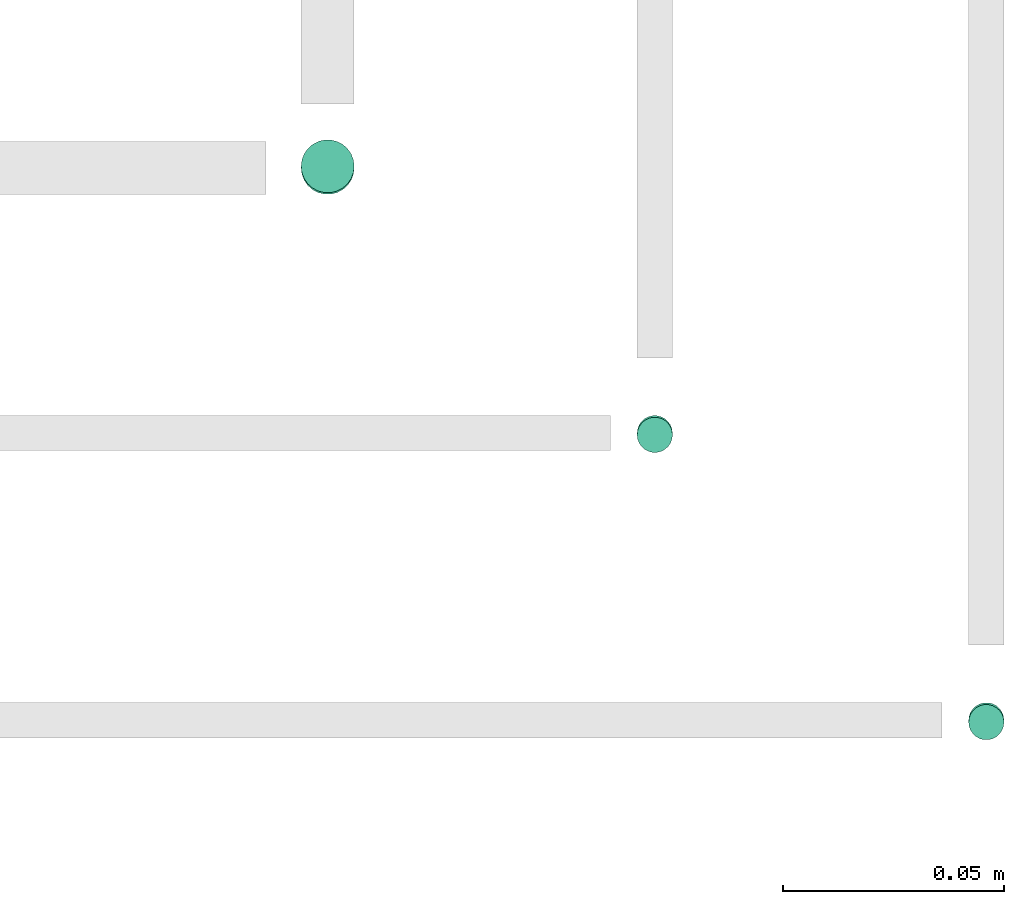
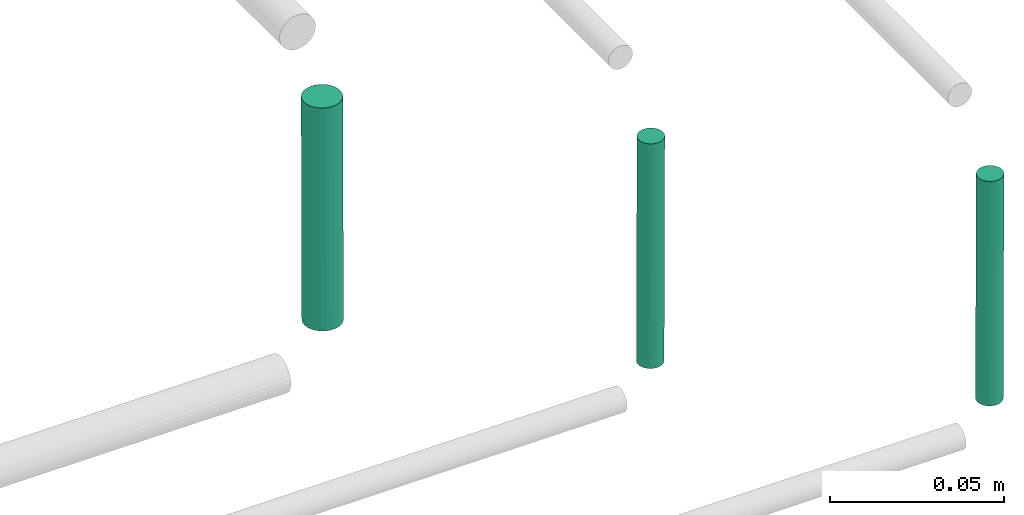
# One storey, part 290 of 331: 3 flow segments.
"""IFC2X3 building model written with IfcOpenShell, lengths in millimetres."""

from ifc_helpers import new_model, entity, si_unit, converted_unit, derived_unit, direction, frame, frame_2d, origin, origin_2d_with_axis, place, context, subcontext, project, spatial, circle, extrude, type_object, element, save


model = new_model("IFC2X3")

# Units and contexts
model_context = context("Model", 3, precision=0.01, world=origin(), true_north=direction((6.12303176911189e-17, 1.0)))
body_context = subcontext(model_context, "Body", "Model", "MODEL_VIEW")
ifc_project = project(units=[si_unit("LENGTHUNIT", "METRE", prefix="MILLI"), si_unit("AREAUNIT", "SQUARE_METRE"), si_unit("VOLUMEUNIT", "CUBIC_METRE"), converted_unit("PLANEANGLEUNIT", "DEGREE", entity("IfcRatioMeasure", 0.0174532925199433), si_unit("PLANEANGLEUNIT", "RADIAN"), dimensions=[0, 0, 0, 0, 0, 0, 0]), si_unit("MASSUNIT", "GRAM", prefix="KILO"), derived_unit("MASSDENSITYUNIT", [(si_unit("MASSUNIT", "GRAM", prefix="KILO"), 1), (si_unit("LENGTHUNIT", "METRE"), -3)]), derived_unit("MOMENTOFINERTIAUNIT", [(si_unit("LENGTHUNIT", "METRE"), 4)]), si_unit("TIMEUNIT", "SECOND"), si_unit("FREQUENCYUNIT", "HERTZ"), si_unit("THERMODYNAMICTEMPERATUREUNIT", "DEGREE_CELSIUS"), derived_unit("THERMALTRANSMITTANCEUNIT", [(si_unit("MASSUNIT", "GRAM", prefix="KILO"), 1), (si_unit("THERMODYNAMICTEMPERATUREUNIT", "KELVIN"), -1), (si_unit("TIMEUNIT", "SECOND"), -3)]), derived_unit("VOLUMETRICFLOWRATEUNIT", [(si_unit("LENGTHUNIT", "METRE"), 3), (si_unit("TIMEUNIT", "SECOND"), -1)]), derived_unit("MASSFLOWRATEUNIT", [(si_unit("MASSUNIT", "GRAM", prefix="KILO"), 1), (si_unit("TIMEUNIT", "SECOND"), -1)]), derived_unit("ROTATIONALFREQUENCYUNIT", [(si_unit("TIMEUNIT", "SECOND"), -1)]), si_unit("ELECTRICCURRENTUNIT", "AMPERE"), si_unit("ELECTRICVOLTAGEUNIT", "VOLT"), si_unit("POWERUNIT", "WATT"), si_unit("FORCEUNIT", "NEWTON", prefix="KILO"), si_unit("ILLUMINANCEUNIT", "LUX"), si_unit("LUMINOUSFLUXUNIT", "LUMEN"), si_unit("LUMINOUSINTENSITYUNIT", "CANDELA"), derived_unit("USERDEFINED", [(si_unit("MASSUNIT", "GRAM", prefix="KILO"), -1), (si_unit("LENGTHUNIT", "METRE"), -2), (si_unit("TIMEUNIT", "SECOND"), 3), (si_unit("LUMINOUSFLUXUNIT", "LUMEN"), 1)]), derived_unit("LINEARVELOCITYUNIT", [(si_unit("LENGTHUNIT", "METRE"), 1), (si_unit("TIMEUNIT", "SECOND"), -1)]), si_unit("PRESSUREUNIT", "PASCAL"), derived_unit("USERDEFINED", [(si_unit("LENGTHUNIT", "METRE"), -2), (si_unit("MASSUNIT", "GRAM", prefix="KILO"), 1), (si_unit("TIMEUNIT", "SECOND"), -2)]), derived_unit("LINEARFORCEUNIT", [(si_unit("MASSUNIT", "GRAM", prefix="KILO"), 1), (si_unit("LENGTHUNIT", "METRE"), 1), (si_unit("TIMEUNIT", "SECOND"), -2), (si_unit("LENGTHUNIT", "METRE"), -1)]), derived_unit("PLANARFORCEUNIT", [(si_unit("MASSUNIT", "GRAM", prefix="KILO"), 1), (si_unit("LENGTHUNIT", "METRE"), 1), (si_unit("TIMEUNIT", "SECOND"), -2), (si_unit("LENGTHUNIT", "METRE"), -2)])], contexts=[model_context])

# Site, building, storey
site_placement = place(None, frame((0.0, -0.00077364408347762, 0.0)))
site = spatial("IfcSite", under=ifc_project, at=site_placement, CompositionType="ELEMENT")
building_placement = place(site_placement, origin())
building = spatial("IfcBuilding", under=site, at=building_placement, CompositionType="ELEMENT")
storey_placement = place(building_placement, origin())
storey = spatial("IfcBuildingStorey", under=building, at=storey_placement, CompositionType="ELEMENT", Elevation=0.0)

# Flow segments
pipe_segment_type = type_object("IfcPipeSegmentType", PredefinedType="NOTDEFINED")
flow_segment_1_placement = place(storey_placement, frame((68012.5100168243, 2567.40460796861, 7263.97282500542)))
element("IfcFlowSegment", 1, at=flow_segment_1_placement, inside=storey, type_object=pipe_segment_type, context=body_context, shape_type="SweptSolid", body=[
    extrude(circle(Radius=6.0, at=origin_2d_with_axis()), frame((7.59527223591454, 7.59521133747482, 0.0270328982179876), z_axis=(0.0, 0.00450548303622422, 0.999989850259797), x_axis=(1.0, 0.0, 0.0)), (0.0, 0.0, 1.0), 78.0009337855729),
])
flow_segment_2_placement = place(storey_placement, frame((68088.5232052591, 2508.9909035141, 7259.98153178214)))
element("IfcFlowSegment", 2, at=flow_segment_2_placement, inside=storey, type_object=pipe_segment_type, context=body_context, shape_type="SweptSolid", body=[
    extrude(circle(Radius=4.0, at=frame_2d((0.0, -4.96239413416384e-15), x_axis=(1.0, 0.0))), frame((5.59527223591499, 5.59523023444986, 79.0201632511465), z_axis=(0.0, 0.0045826436133296, -0.999989499633628), x_axis=(-1.0, 0.0, 0.0)), (0.0, 0.0, 1.0), 79.0026622336935),
])
flow_segment_3_placement = place(storey_placement, frame((68163.5232052591, 2443.99091657, 7259.9788753162)))
element("IfcFlowSegment", 3, at=flow_segment_3_placement, inside=storey, type_object=pipe_segment_type, context=body_context, shape_type="SweptSolid", body=[
    extrude(circle(Radius=4.0, at=origin_2d_with_axis()), frame((5.59527223591499, 5.59521717855424, 79.022819717083), z_axis=(0.0, 0.00524676009624323, -0.999986235659518), x_axis=(-1.0, 0.0, 0.0)), (0.0, 0.0, 1.0), 79.0029200997981),
])

save(model, "model.ifc")
